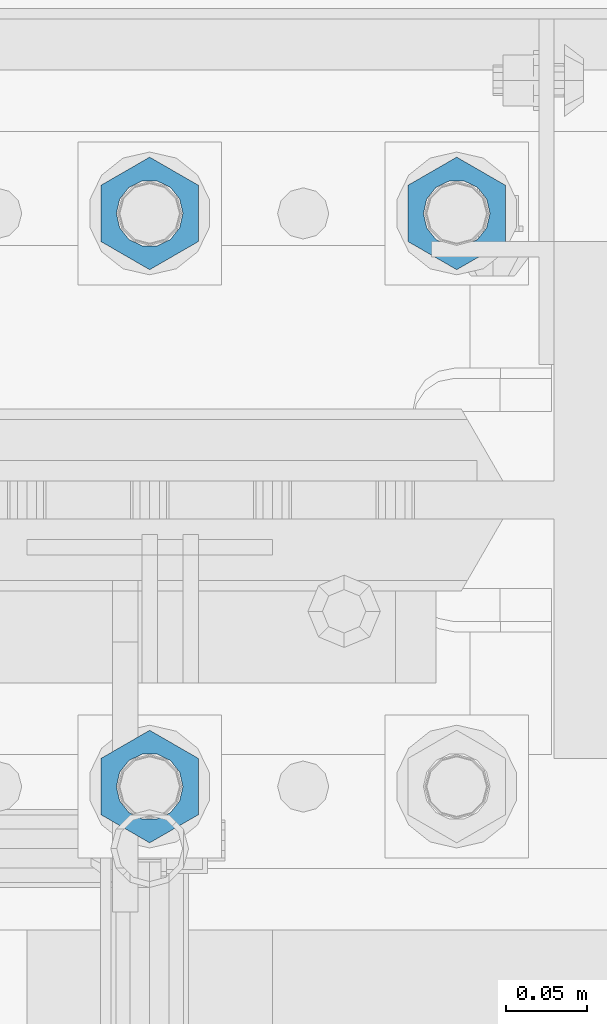
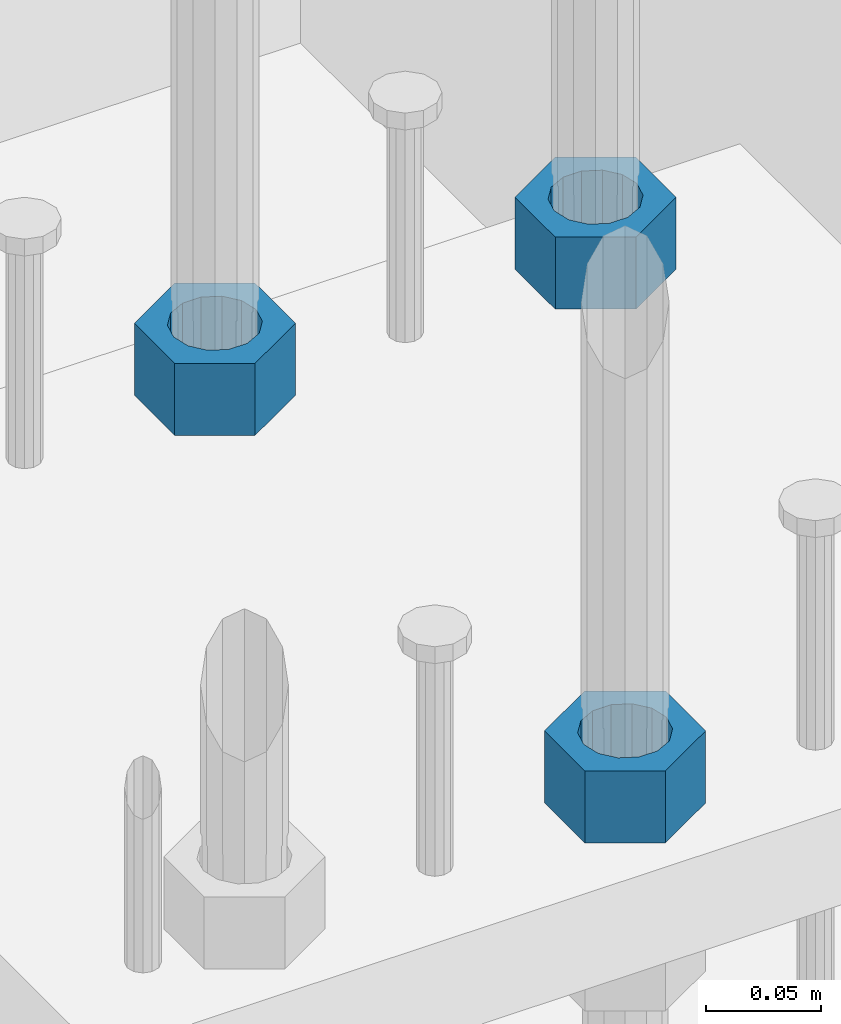
# One storey, part 1400 of 1876: 3 beams, 1 element without a shape of its own.
"""IFC2X3 building model written with IfcOpenShell, lengths in millimetres."""

from ifc_helpers import new_model, si_unit, frame, origin_with_axes, place, context, subcontext, project, spatial, faceted_brep, material, type_object, element, aggregate, save


model = new_model("IFC2X3")

# Units and contexts
model_context = context("Model", 3, precision=1e-05, world=origin_with_axes())
body_context = subcontext(model_context, "Body", "Model", "MODEL_VIEW")
ifc_project = project(units=[si_unit("LENGTHUNIT", "METRE", prefix="MILLI"), si_unit("AREAUNIT", "SQUARE_METRE"), si_unit("VOLUMEUNIT", "CUBIC_METRE"), si_unit("MASSUNIT", "GRAM", prefix="KILO"), si_unit("TIMEUNIT", "SECOND"), si_unit("PLANEANGLEUNIT", "RADIAN"), si_unit("SOLIDANGLEUNIT", "STERADIAN"), si_unit("THERMODYNAMICTEMPERATUREUNIT", "DEGREE_CELSIUS"), si_unit("LUMINOUSINTENSITYUNIT", "LUMEN")], contexts=[model_context])

# Site, building, storey
site_placement = place(None, origin_with_axes())
site = spatial("IfcSite", under=ifc_project, at=site_placement, CompositionType="ELEMENT")
building_placement = place(site_placement, origin_with_axes())
building = spatial("IfcBuilding", under=site, at=building_placement, Name="Undefined", CompositionType="ELEMENT")
storey_placement = place(building_placement, origin_with_axes())
storey = spatial("IfcBuildingStorey", under=building, at=storey_placement, Name="Undefined", CompositionType="ELEMENT", Elevation=0.0)

# Assembly, beams
assembly_placement = place(storey_placement, origin_with_axes())
assembly = element("IfcElementAssembly", 1, at=assembly_placement, inside=storey, Name="TEMPLATE", AssemblyPlace="NOTDEFINED", PredefinedType="RIGID_FRAME")
ifc_material = material(Name="STEEL/A563")
beam_type = type_object("IfcBeamType", Name="1-1/2_HEAVY_HEX_NUT", PredefinedType="NOTDEFINED")
beam_1_placement = place(assembly_placement, frame((7810.5, 13893.8, -698.5), z_axis=(-1.0, 0.0, 0.0), x_axis=(0.0, 0.0, -1.0)))
beam_1 = element("IfcBeam", 2, at=beam_1_placement, type_object=beam_type, material=ifc_material, Name="NUT", ObjectType="1-1/2_HEAVY_HEX_NUT", context=body_context, shape_type="Brep", body=[
    faceted_brep([(0.0, -34.9199981689453, 0.0), (0.0, -17.4599990844727, -30.25), (38.1, -17.4599990844727, -30.25), (38.1, -34.9199981689453, 0.0), (0.0, 17.4599990844727, -30.25), (38.1, 17.4599990844727, -30.25), (0.0, 34.9199981689453, 0.0), (38.1, 34.9199981689453, 0.0), (0.0, 17.4599990844727, 30.25), (38.1, 17.4599990844727, 30.25), (0.0, -17.4599990844727, 30.25), (38.1, -17.4599990844727, 30.25), (0.0, 0.0, 20.6399993896484), (0.0, 8.95536011056538, 18.5959968835978), (38.1, 8.95536011056447, 18.595996883598), (38.1, 0.0, 20.6399993896484), (0.0, 16.1370013209489, 12.8688291298158), (38.1, 16.137001320948, 12.8688291298162), (0.0, 20.1225115123834, 4.59283194104228), (38.1, 20.1225115123843, 4.59283194104222), (0.0, 20.1225115123834, -4.59283194104228), (38.1, 20.1225115123843, -4.59283194104239), (0.0, 16.1370013209489, -12.8688291298167), (38.1, 16.137001320948, -12.8688291298163), (0.0, 8.95536011056538, -18.5959968835978), (38.1, 8.95536011056447, -18.5959968835982), (0.0, 0.0, -20.6399993896484), (38.1, 0.0, -20.6399993896484), (0.0, -8.95536011056538, -18.5959968835978), (38.1, -8.95536011056447, -18.595996883598), (0.0, -16.1370013209489, -12.8688291298158), (38.1, -16.137001320948, -12.8688291298162), (0.0, -20.1225115123834, -4.59283194104228), (38.1, -20.1225115123843, -4.59283194104222), (0.0, -20.1225115123834, 4.59283194104228), (38.1, -20.1225115123843, 4.59283194104239), (0.0, -16.1370013209489, 12.8688291298167), (38.1, -16.137001320948, 12.8688291298163), (0.0, -8.95536011056538, 18.5959968835978), (38.1, -8.95536011056447, 18.5959968835982)], [[[0, 1, 2, 3]], [[1, 4, 5, 2]], [[4, 6, 7, 5]], [[6, 8, 9, 7]], [[8, 10, 11, 9]], [[10, 0, 3, 11]], [[12, 13, 14, 15]], [[13, 16, 17, 14]], [[16, 18, 19, 17]], [[18, 20, 21, 19]], [[20, 22, 23, 21]], [[22, 24, 25, 23]], [[24, 26, 27, 25]], [[26, 28, 29, 27]], [[28, 30, 31, 29]], [[30, 32, 33, 31]], [[32, 34, 35, 33]], [[34, 36, 37, 35]], [[36, 38, 39, 37]], [[38, 12, 15, 39]], [[5, 7, 9, 11, 3, 2], [17, 19, 21, 23, 25, 27, 29, 31, 33, 35, 37, 39, 15, 14]], [[10, 8, 6, 4, 1, 0], [38, 36, 34, 32, 30, 28, 26, 24, 22, 20, 18, 16, 13, 12]]]),
])
beam_2_placement = place(assembly_placement, frame((7620.0, 13538.2, -698.5), z_axis=(1.0, 0.0, 0.0), x_axis=(0.0, 0.0, -1.0)))
beam_2 = element("IfcBeam", 3, at=beam_2_placement, type_object=beam_type, material=ifc_material, Name="NUT", ObjectType="1-1/2_HEAVY_HEX_NUT", context=body_context, shape_type="Brep", body=[
    faceted_brep([(0.0, -34.9199981689453, 0.0), (0.0, -17.4599990844727, -30.25), (38.1, -17.4599990844727, -30.25), (38.1, -34.9199981689453, 0.0), (0.0, 17.4599990844727, -30.25), (38.1, 17.4599990844727, -30.25), (0.0, 34.9199981689453, 0.0), (38.1, 34.9199981689453, 0.0), (0.0, 17.4599990844727, 30.25), (38.1, 17.4599990844727, 30.25), (0.0, -17.4599990844727, 30.25), (38.1, -17.4599990844727, 30.25), (0.0, 0.0, 20.6399993896484), (0.0, 8.95536011056538, 18.5959968835978), (38.1, 8.95536011056447, 18.595996883598), (38.1, 0.0, 20.6399993896484), (0.0, 16.1370013209489, 12.8688291298158), (38.1, 16.137001320948, 12.8688291298162), (0.0, 20.1225115123834, 4.59283194104228), (38.1, 20.1225115123843, 4.59283194104222), (0.0, 20.1225115123834, -4.59283194104228), (38.1, 20.1225115123843, -4.59283194104239), (0.0, 16.1370013209489, -12.8688291298167), (38.1, 16.137001320948, -12.8688291298163), (0.0, 8.95536011056538, -18.5959968835978), (38.1, 8.95536011056447, -18.5959968835982), (0.0, 0.0, -20.6399993896484), (38.1, 0.0, -20.6399993896484), (0.0, -8.95536011056538, -18.5959968835978), (38.1, -8.95536011056447, -18.595996883598), (0.0, -16.1370013209489, -12.8688291298158), (38.1, -16.137001320948, -12.8688291298162), (0.0, -20.1225115123834, -4.59283194104228), (38.1, -20.1225115123843, -4.59283194104222), (0.0, -20.1225115123834, 4.59283194104228), (38.1, -20.1225115123843, 4.59283194104239), (0.0, -16.1370013209489, 12.8688291298167), (38.1, -16.137001320948, 12.8688291298163), (0.0, -8.95536011056538, 18.5959968835978), (38.1, -8.95536011056447, 18.5959968835982)], [[[0, 1, 2, 3]], [[1, 4, 5, 2]], [[4, 6, 7, 5]], [[6, 8, 9, 7]], [[8, 10, 11, 9]], [[10, 0, 3, 11]], [[12, 13, 14, 15]], [[13, 16, 17, 14]], [[16, 18, 19, 17]], [[18, 20, 21, 19]], [[20, 22, 23, 21]], [[22, 24, 25, 23]], [[24, 26, 27, 25]], [[26, 28, 29, 27]], [[28, 30, 31, 29]], [[30, 32, 33, 31]], [[32, 34, 35, 33]], [[34, 36, 37, 35]], [[36, 38, 39, 37]], [[38, 12, 15, 39]], [[5, 7, 9, 11, 3, 2], [17, 19, 21, 23, 25, 27, 29, 31, 33, 35, 37, 39, 15, 14]], [[10, 8, 6, 4, 1, 0], [38, 36, 34, 32, 30, 28, 26, 24, 22, 20, 18, 16, 13, 12]]]),
])
beam_3_placement = place(assembly_placement, frame((7620.0, 13893.8, -698.5), z_axis=(-1.0, 0.0, 0.0), x_axis=(0.0, 0.0, -1.0)))
beam_3 = element("IfcBeam", 4, at=beam_3_placement, type_object=beam_type, material=ifc_material, Name="NUT", ObjectType="1-1/2_HEAVY_HEX_NUT", context=body_context, shape_type="Brep", body=[
    faceted_brep([(0.0, -34.9199981689453, 0.0), (0.0, -17.4599990844727, -30.25), (38.1, -17.4599990844727, -30.25), (38.1, -34.9199981689453, 0.0), (0.0, 17.4599990844727, -30.25), (38.1, 17.4599990844727, -30.25), (0.0, 34.9199981689453, 0.0), (38.1, 34.9199981689453, 0.0), (0.0, 17.4599990844727, 30.25), (38.1, 17.4599990844727, 30.25), (0.0, -17.4599990844727, 30.25), (38.1, -17.4599990844727, 30.25), (0.0, 0.0, 20.6399993896484), (0.0, 8.95536011056538, 18.5959968835978), (38.1, 8.95536011056447, 18.595996883598), (38.1, 0.0, 20.6399993896484), (0.0, 16.1370013209489, 12.8688291298158), (38.1, 16.137001320948, 12.8688291298162), (0.0, 20.1225115123834, 4.59283194104228), (38.1, 20.1225115123843, 4.59283194104222), (0.0, 20.1225115123834, -4.59283194104228), (38.1, 20.1225115123843, -4.59283194104239), (0.0, 16.1370013209489, -12.8688291298167), (38.1, 16.137001320948, -12.8688291298163), (0.0, 8.95536011056538, -18.5959968835978), (38.1, 8.95536011056447, -18.5959968835982), (0.0, 0.0, -20.6399993896484), (38.1, 0.0, -20.6399993896484), (0.0, -8.95536011056538, -18.5959968835978), (38.1, -8.95536011056447, -18.595996883598), (0.0, -16.1370013209489, -12.8688291298158), (38.1, -16.137001320948, -12.8688291298162), (0.0, -20.1225115123834, -4.59283194104228), (38.1, -20.1225115123843, -4.59283194104222), (0.0, -20.1225115123834, 4.59283194104228), (38.1, -20.1225115123843, 4.59283194104239), (0.0, -16.1370013209489, 12.8688291298167), (38.1, -16.137001320948, 12.8688291298163), (0.0, -8.95536011056538, 18.5959968835978), (38.1, -8.95536011056447, 18.5959968835982)], [[[0, 1, 2, 3]], [[1, 4, 5, 2]], [[4, 6, 7, 5]], [[6, 8, 9, 7]], [[8, 10, 11, 9]], [[10, 0, 3, 11]], [[12, 13, 14, 15]], [[13, 16, 17, 14]], [[16, 18, 19, 17]], [[18, 20, 21, 19]], [[20, 22, 23, 21]], [[22, 24, 25, 23]], [[24, 26, 27, 25]], [[26, 28, 29, 27]], [[28, 30, 31, 29]], [[30, 32, 33, 31]], [[32, 34, 35, 33]], [[34, 36, 37, 35]], [[36, 38, 39, 37]], [[38, 12, 15, 39]], [[5, 7, 9, 11, 3, 2], [17, 19, 21, 23, 25, 27, 29, 31, 33, 35, 37, 39, 15, 14]], [[10, 8, 6, 4, 1, 0], [38, 36, 34, 32, 30, 28, 26, 24, 22, 20, 18, 16, 13, 12]]]),
])
aggregate(assembly, [beam_1, beam_2, beam_3])

save(model, "model.ifc")
